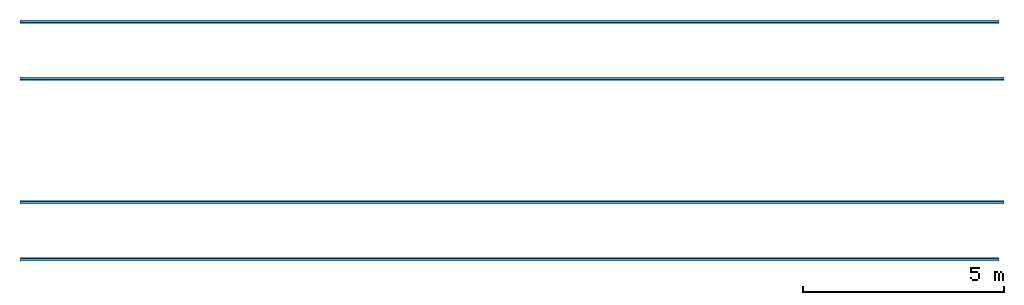
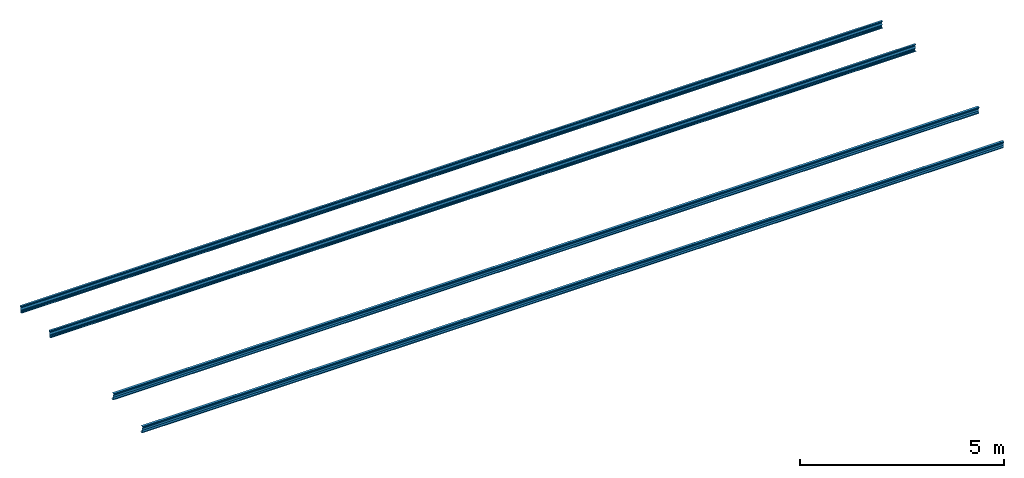
# One storey: 4 beams.
"""IFC2X3 building model written with IfcOpenShell, lengths in millimetres."""

from ifc_helpers import new_model, entity, si_unit, converted_unit, money_unit, point, direction, frame, frame_2d, origin_with_axes, place, context, subcontext, project, spatial, polyline, circle_curve, parameter, trimmed, segment, composite_curve, outline, extrude, material, type_object, element, save


model = new_model("IFC2X3")

# Units and contexts
model_context = context("Model", 3, precision=1e-05, world=origin_with_axes(), true_north=direction((0.0, 1.0)))
body_context = subcontext(model_context, "Body", "Model", "MODEL_VIEW")
ifc_project = project(units=[si_unit("LENGTHUNIT", "METRE", prefix="MILLI"), si_unit("AREAUNIT", "SQUARE_METRE"), si_unit("VOLUMEUNIT", "CUBIC_METRE"), converted_unit("PLANEANGLEUNIT", "DEGREE", entity("IfcPlaneAngleMeasure", 0.0174532925199), si_unit("PLANEANGLEUNIT", "RADIAN"), dimensions=[0, 0, 0, 0, 0, 0, 0]), si_unit("SOLIDANGLEUNIT", "STERADIAN"), money_unit("USD"), converted_unit("TIMEUNIT", "Year", entity("IfcTimeMeasure", 31556926.0), si_unit("TIMEUNIT", "SECOND"), dimensions=[0, 0, 0, 0, 0, 0, 0]), si_unit("MASSUNIT", "GRAM"), si_unit("THERMODYNAMICTEMPERATUREUNIT", "DEGREE_CELSIUS"), si_unit("LUMINOUSINTENSITYUNIT", "LUMEN")], contexts=[model_context])

# Site, building, storey
site_placement = place(None, origin_with_axes())
site = spatial("IfcSite", under=ifc_project, at=site_placement, CompositionType="ELEMENT")
building_placement = place(site_placement, origin_with_axes())
building = spatial("IfcBuilding", under=site, at=building_placement, CompositionType="ELEMENT")
storey_placement = place(building_placement, frame((0.0, 0.0, 74605.0), z_axis=(0.0, 0.0, 1.0), x_axis=(1.0, 0.0, 0.0)))
storey = spatial("IfcBuildingStorey", under=building, at=storey_placement, CompositionType="ELEMENT", Elevation=74605.0)

# Beams
ifc_material = material(Name="Metal - Steel 43-275")
beam_type_1 = type_object("IfcBeamType", PredefinedType="NOTDEFINED")
beam_1_placement = place(storey_placement, frame((16408.2045075, 5111.90364585, -29.9916343169), z_axis=(0.0, 0.0, 1.0), x_axis=(0.0, 1.0, 0.0)))
element("IfcBeam", 1, at=beam_1_placement, inside=storey, type_object=beam_type_1, material=ifc_material, Name="Light Gauge-Kingspan Purlins:M", ObjectType="Light Gauge-Kingspan Purlins:M", context=body_context, shape_type="SweptSolid", body=[
    extrude(outline(composite_curve([segment(polyline([(-33.5333333333, -102.5), (25.0666666666, -102.5)]), True, "CONTINUOUS"), segment(trimmed(circle_curve(frame_2d((25.0666666666, -99.3), x_axis=(0.0, -1.0)), 3.2), [point((25.0666666666, -102.5)), parameter(0.0)], [point((28.2666666666, -99.3)), parameter(90.0)], True, "CARTESIAN"), True, "CONTINUOUS"), segment(polyline([(28.2666666666, -99.3), (28.2666666666, -91.7)]), True, "CONTINUOUS"), segment(trimmed(circle_curve(frame_2d((25.0666666666, -91.7), x_axis=(1.0, 0.0)), 3.2), [point((28.2666666666, -91.7)), parameter(0.0)], [point((25.0666666666, -88.5)), parameter(90.0)], True, "CARTESIAN"), True, "CONTINUOUS"), segment(polyline([(25.0666666666, -88.5), (16.2666666666, -88.5), (16.2666666666, -90.1), (25.0666666666, -90.1)]), True, "CONTINUOUS"), segment(trimmed(circle_curve(frame_2d((25.0666666666, -91.7), x_axis=(1.0, 0.0)), 1.6), [point((25.0666666666, -90.1)), parameter(90.0)], [point((26.6666666666, -91.7)), parameter(0.0)], False, "CARTESIAN"), True, "CONTINUOUS"), segment(polyline([(26.6666666666, -91.7), (26.6666666666, -99.3)]), True, "CONTINUOUS"), segment(trimmed(circle_curve(frame_2d((25.0666666666, -99.3), x_axis=(0.0, -1.0)), 1.6), [point((26.6666666666, -99.3)), parameter(90.0)], [point((25.0666666666, -100.9)), parameter(0.0)], False, "CARTESIAN"), True, "CONTINUOUS"), segment(polyline([(25.0666666666, -100.9), (-33.5333333334, -100.9)]), True, "CONTINUOUS"), segment(trimmed(circle_curve(frame_2d((-33.5333333334, -99.3), x_axis=(-1.0, 0.0)), 1.6), [point((-33.5333333334, -100.9)), parameter(90.0)], [point((-35.1333333334, -99.3)), parameter(0.0)], False, "CARTESIAN"), True, "CONTINUOUS"), segment(polyline([(-35.1333333334, -99.3), (-35.1333333334, -70.8953456886), (-15.1333333334, -32.8953456886), (-15.1333333334, 32.8953456886), (-35.1333333334, 70.8953456886), (-35.1333333334, 99.3)]), True, "CONTINUOUS"), segment(trimmed(circle_curve(frame_2d((-33.5333333334, 99.3), x_axis=(0.0, 1.0)), 1.6), [point((-35.1333333334, 99.3)), parameter(90.0)], [point((-33.5333333334, 100.9)), parameter(0.0)], False, "CARTESIAN"), True, "CONTINUOUS"), segment(polyline([(-33.5333333334, 100.9), (25.0666666666, 100.9)]), True, "CONTINUOUS"), segment(trimmed(circle_curve(frame_2d((25.0666666666, 99.3), x_axis=(1.0, 0.0)), 1.6), [point((25.0666666666, 100.9)), parameter(90.0)], [point((26.6666666666, 99.3)), parameter(0.0)], False, "CARTESIAN"), True, "CONTINUOUS"), segment(polyline([(26.6666666666, 99.3), (26.6666666666, 91.7)]), True, "CONTINUOUS"), segment(trimmed(circle_curve(frame_2d((25.0666666666, 91.7), x_axis=(0.0, -1.0)), 1.6), [point((26.6666666666, 91.7)), parameter(90.0)], [point((25.0666666666, 90.1)), parameter(0.0)], False, "CARTESIAN"), True, "CONTINUOUS"), segment(polyline([(25.0666666666, 90.1), (16.2666666666, 90.1), (16.2666666666, 88.5), (25.0666666666, 88.5)]), True, "CONTINUOUS"), segment(trimmed(circle_curve(frame_2d((25.0666666666, 91.7), x_axis=(0.0, -1.0)), 3.2), [point((25.0666666666, 88.5)), parameter(0.0)], [point((28.2666666666, 91.7)), parameter(90.0)], True, "CARTESIAN"), True, "CONTINUOUS"), segment(polyline([(28.2666666666, 91.7), (28.2666666666, 99.3)]), True, "CONTINUOUS"), segment(trimmed(circle_curve(frame_2d((25.0666666666, 99.3), x_axis=(1.0, 0.0)), 3.2), [point((28.2666666666, 99.3)), parameter(0.0)], [point((25.0666666666, 102.5)), parameter(90.0)], True, "CARTESIAN"), True, "CONTINUOUS"), segment(polyline([(25.0666666666, 102.5), (-33.5333333334, 102.5)]), True, "CONTINUOUS"), segment(trimmed(circle_curve(frame_2d((-33.5333333334, 99.3), x_axis=(0.0, 1.0)), 3.2), [point((-33.5333333334, 102.5)), parameter(0.0)], [point((-36.7333333334, 99.3)), parameter(90.0)], True, "CARTESIAN"), True, "CONTINUOUS"), segment(polyline([(-36.7333333334, 99.3), (-36.7333333334, 70.5), (-16.7333333334, 32.5), (-16.7333333334, -32.5), (-36.7333333334, -70.5), (-36.7333333334, -99.3)]), True, "CONTINUOUS"), segment(trimmed(circle_curve(frame_2d((-33.5333333334, -99.3), x_axis=(-1.0, 0.0)), 3.20000000005), [point((-36.7333333334, -99.3)), parameter(0.0)], [point((-33.5333333333, -102.5)), parameter(90.0)], True, "CARTESIAN"), True, "CONTINUOUS")], self_intersect=False)), frame((0.0, 24528.0, 0.0), z_axis=(0.0, -1.0, 0.0), x_axis=(-0.996194698092, 0.0, 0.0871557427478)), (0.0, 0.0, 1.0), 24528.0),
])
beam_2_placement = place(storey_placement, frame((16287.2045075, 6534.46967472, -154.450034961), z_axis=(0.0, 0.0, 1.0), x_axis=(0.0, 1.0, 0.0)))
element("IfcBeam", 2, at=beam_2_placement, inside=storey, type_object=beam_type_1, material=ifc_material, Name="Light Gauge-Kingspan Purlins:M", ObjectType="Light Gauge-Kingspan Purlins:M", context=body_context, shape_type="SweptSolid", body=[
    extrude(outline(composite_curve([segment(polyline([(-33.5333333333, -102.5), (25.0666666666, -102.5)]), True, "CONTINUOUS"), segment(trimmed(circle_curve(frame_2d((25.0666666666, -99.3), x_axis=(0.0, -1.0)), 3.2), [point((25.0666666666, -102.5)), parameter(0.0)], [point((28.2666666666, -99.3)), parameter(90.0)], True, "CARTESIAN"), True, "CONTINUOUS"), segment(polyline([(28.2666666666, -99.3), (28.2666666666, -91.7)]), True, "CONTINUOUS"), segment(trimmed(circle_curve(frame_2d((25.0666666666, -91.7), x_axis=(1.0, 0.0)), 3.2), [point((28.2666666666, -91.7)), parameter(0.0)], [point((25.0666666666, -88.5)), parameter(90.0)], True, "CARTESIAN"), True, "CONTINUOUS"), segment(polyline([(25.0666666666, -88.5), (16.2666666666, -88.5), (16.2666666666, -90.1), (25.0666666666, -90.1)]), True, "CONTINUOUS"), segment(trimmed(circle_curve(frame_2d((25.0666666666, -91.7), x_axis=(1.0, 0.0)), 1.6), [point((25.0666666666, -90.1)), parameter(90.0)], [point((26.6666666666, -91.7)), parameter(0.0)], False, "CARTESIAN"), True, "CONTINUOUS"), segment(polyline([(26.6666666666, -91.7), (26.6666666666, -99.3)]), True, "CONTINUOUS"), segment(trimmed(circle_curve(frame_2d((25.0666666666, -99.3), x_axis=(0.0, -1.0)), 1.6), [point((26.6666666666, -99.3)), parameter(90.0)], [point((25.0666666666, -100.9)), parameter(0.0)], False, "CARTESIAN"), True, "CONTINUOUS"), segment(polyline([(25.0666666666, -100.9), (-33.5333333334, -100.9)]), True, "CONTINUOUS"), segment(trimmed(circle_curve(frame_2d((-33.5333333334, -99.3), x_axis=(-1.0, 0.0)), 1.6), [point((-33.5333333334, -100.9)), parameter(90.0)], [point((-35.1333333334, -99.3)), parameter(0.0)], False, "CARTESIAN"), True, "CONTINUOUS"), segment(polyline([(-35.1333333334, -99.3), (-35.1333333334, -70.8953456886), (-15.1333333334, -32.8953456886), (-15.1333333334, 32.8953456886), (-35.1333333334, 70.8953456886), (-35.1333333334, 99.3)]), True, "CONTINUOUS"), segment(trimmed(circle_curve(frame_2d((-33.5333333334, 99.3), x_axis=(0.0, 1.0)), 1.6), [point((-35.1333333334, 99.3)), parameter(90.0)], [point((-33.5333333334, 100.9)), parameter(0.0)], False, "CARTESIAN"), True, "CONTINUOUS"), segment(polyline([(-33.5333333334, 100.9), (25.0666666666, 100.9)]), True, "CONTINUOUS"), segment(trimmed(circle_curve(frame_2d((25.0666666666, 99.3), x_axis=(1.0, 0.0)), 1.6), [point((25.0666666666, 100.9)), parameter(90.0)], [point((26.6666666666, 99.3)), parameter(0.0)], False, "CARTESIAN"), True, "CONTINUOUS"), segment(polyline([(26.6666666666, 99.3), (26.6666666666, 91.7)]), True, "CONTINUOUS"), segment(trimmed(circle_curve(frame_2d((25.0666666666, 91.7), x_axis=(0.0, -1.0)), 1.6), [point((26.6666666666, 91.7)), parameter(90.0)], [point((25.0666666666, 90.1)), parameter(0.0)], False, "CARTESIAN"), True, "CONTINUOUS"), segment(polyline([(25.0666666666, 90.1), (16.2666666666, 90.1), (16.2666666666, 88.5), (25.0666666666, 88.5)]), True, "CONTINUOUS"), segment(trimmed(circle_curve(frame_2d((25.0666666666, 91.7), x_axis=(0.0, -1.0)), 3.2), [point((25.0666666666, 88.5)), parameter(0.0)], [point((28.2666666666, 91.7)), parameter(90.0)], True, "CARTESIAN"), True, "CONTINUOUS"), segment(polyline([(28.2666666666, 91.7), (28.2666666666, 99.3)]), True, "CONTINUOUS"), segment(trimmed(circle_curve(frame_2d((25.0666666666, 99.3), x_axis=(1.0, 0.0)), 3.2), [point((28.2666666666, 99.3)), parameter(0.0)], [point((25.0666666666, 102.5)), parameter(90.0)], True, "CARTESIAN"), True, "CONTINUOUS"), segment(polyline([(25.0666666666, 102.5), (-33.5333333334, 102.5)]), True, "CONTINUOUS"), segment(trimmed(circle_curve(frame_2d((-33.5333333334, 99.3), x_axis=(0.0, 1.0)), 3.2), [point((-33.5333333334, 102.5)), parameter(0.0)], [point((-36.7333333334, 99.3)), parameter(90.0)], True, "CARTESIAN"), True, "CONTINUOUS"), segment(polyline([(-36.7333333334, 99.3), (-36.7333333334, 70.5), (-16.7333333334, 32.5), (-16.7333333334, -32.5), (-36.7333333334, -70.5), (-36.7333333334, -99.3)]), True, "CONTINUOUS"), segment(trimmed(circle_curve(frame_2d((-33.5333333334, -99.3), x_axis=(-1.0, 0.0)), 3.20000000005), [point((-36.7333333334, -99.3)), parameter(0.0)], [point((-33.5333333333, -102.5)), parameter(90.0)], True, "CARTESIAN"), True, "CONTINUOUS")], self_intersect=False)), frame((0.0, 24407.0, 0.0), z_axis=(0.0, -1.0, 0.0), x_axis=(-0.996194698092, 0.0, 0.0871557427478)), (0.0, 0.0, 1.0), 24407.0),
])
beam_type_2 = type_object("IfcBeamType", PredefinedType="NOTDEFINED")
beam_3_placement = place(storey_placement, frame((16287.2045075, 620.490168663, -154.450034961), z_axis=(0.0, 0.0, 1.0), x_axis=(0.0, 1.0, 0.0)))
element("IfcBeam", 3, at=beam_3_placement, inside=storey, type_object=beam_type_2, material=ifc_material, Name="Light Gauge-Kingspan Purlins:M", ObjectType="Light Gauge-Kingspan Purlins:M", context=body_context, shape_type="SweptSolid", body=[
    extrude(outline(composite_curve([segment(polyline([(91.7, -28.2666666667), (99.3, -28.2666666667)]), True, "CONTINUOUS"), segment(trimmed(circle_curve(frame_2d((99.3, -25.0666666667), x_axis=(0.0, -1.0)), 3.2), [point((99.3, -28.2666666667)), parameter(0.0)], [point((102.5, -25.0666666667)), parameter(90.0)], True, "CARTESIAN"), True, "CONTINUOUS"), segment(polyline([(102.5, -25.0666666667), (102.5, 33.5333333333)]), True, "CONTINUOUS"), segment(trimmed(circle_curve(frame_2d((99.3, 33.5333333333), x_axis=(1.0, 0.0)), 3.2), [point((102.5, 33.5333333333)), parameter(0.0)], [point((99.3, 36.7333333333)), parameter(90.0)], True, "CARTESIAN"), True, "CONTINUOUS"), segment(polyline([(99.3, 36.7333333333), (70.5, 36.7333333333), (32.5, 16.7333333333), (-32.5, 16.7333333333), (-70.5, 36.7333333334), (-99.3, 36.7333333334)]), True, "CONTINUOUS"), segment(trimmed(circle_curve(frame_2d((-99.3, 33.5333333334), x_axis=(0.0, 1.0)), 3.2), [point((-99.3, 36.7333333334)), parameter(0.0)], [point((-102.5, 33.5333333334)), parameter(90.0)], True, "CARTESIAN"), True, "CONTINUOUS"), segment(polyline([(-102.5, 33.5333333334), (-102.5, -25.0666666666)]), True, "CONTINUOUS"), segment(trimmed(circle_curve(frame_2d((-99.3, -25.0666666666), x_axis=(-1.0, 0.0)), 3.2), [point((-102.5, -25.0666666666)), parameter(0.0)], [point((-99.3, -28.2666666666)), parameter(90.0)], True, "CARTESIAN"), True, "CONTINUOUS"), segment(polyline([(-99.3, -28.2666666666), (-91.7, -28.2666666666)]), True, "CONTINUOUS"), segment(trimmed(circle_curve(frame_2d((-91.7, -25.0666666666), x_axis=(0.0, -1.0)), 3.2), [point((-91.7, -28.2666666666)), parameter(0.0)], [point((-88.5, -25.0666666666)), parameter(90.0)], True, "CARTESIAN"), True, "CONTINUOUS"), segment(polyline([(-88.5, -25.0666666666), (-88.5, -16.2666666666), (-90.1, -16.2666666666), (-90.1, -25.0666666666)]), True, "CONTINUOUS"), segment(trimmed(circle_curve(frame_2d((-91.7, -25.0666666666), x_axis=(0.0, -1.0)), 1.6), [point((-90.1, -25.0666666666)), parameter(90.0)], [point((-91.7, -26.6666666666)), parameter(0.0)], False, "CARTESIAN"), True, "CONTINUOUS"), segment(polyline([(-91.7, -26.6666666666), (-99.3, -26.6666666666)]), True, "CONTINUOUS"), segment(trimmed(circle_curve(frame_2d((-99.3, -25.0666666666), x_axis=(-1.0, 0.0)), 1.6), [point((-99.3, -26.6666666666)), parameter(90.0)], [point((-100.9, -25.0666666666)), parameter(0.0)], False, "CARTESIAN"), True, "CONTINUOUS"), segment(polyline([(-100.9, -25.0666666666), (-100.9, 33.5333333334)]), True, "CONTINUOUS"), segment(trimmed(circle_curve(frame_2d((-99.3, 33.5333333334), x_axis=(0.0, 1.0)), 1.6), [point((-100.9, 33.5333333334)), parameter(90.0)], [point((-99.3, 35.1333333334)), parameter(0.0)], False, "CARTESIAN"), True, "CONTINUOUS"), segment(polyline([(-99.3, 35.1333333334), (-70.8953456886, 35.1333333334), (-32.8953456886, 15.1333333333), (32.8953456886, 15.1333333333), (70.8953456886, 35.1333333333), (99.3, 35.1333333333)]), True, "CONTINUOUS"), segment(trimmed(circle_curve(frame_2d((99.3, 33.5333333333), x_axis=(1.0, 0.0)), 1.6), [point((99.3, 35.1333333333)), parameter(90.0)], [point((100.9, 33.5333333333)), parameter(0.0)], False, "CARTESIAN"), True, "CONTINUOUS"), segment(polyline([(100.9, 33.5333333333), (100.9, -25.0666666667)]), True, "CONTINUOUS"), segment(trimmed(circle_curve(frame_2d((99.3, -25.0666666667), x_axis=(0.0, -1.0)), 1.6), [point((100.9, -25.0666666667)), parameter(90.0)], [point((99.3, -26.6666666667)), parameter(0.0)], False, "CARTESIAN"), True, "CONTINUOUS"), segment(polyline([(99.3, -26.6666666667), (91.7, -26.6666666667)]), True, "CONTINUOUS"), segment(trimmed(circle_curve(frame_2d((91.7, -25.0666666667), x_axis=(-1.0, 0.0)), 1.6), [point((91.7, -26.6666666667)), parameter(90.0)], [point((90.1, -25.0666666667)), parameter(0.0)], False, "CARTESIAN"), True, "CONTINUOUS"), segment(polyline([(90.1, -25.0666666667), (90.1, -16.2666666667), (88.5, -16.2666666667), (88.5, -25.0666666667)]), True, "CONTINUOUS"), segment(trimmed(circle_curve(frame_2d((91.7, -25.0666666667), x_axis=(-1.0, 0.0)), 3.2), [point((88.5, -25.0666666667)), parameter(0.0)], [point((91.7, -28.2666666667)), parameter(90.0)], True, "CARTESIAN"), True, "CONTINUOUS")], self_intersect=False)), frame((0.0, 24407.0, 0.0), z_axis=(0.0, -1.0, 0.0), x_axis=(-0.0871557427479, 0.0, 0.996194698092)), (0.0, 0.0, 1.0), 24407.0),
])
beam_4_placement = place(storey_placement, frame((16408.2045075, 2043.05619754, -29.9916343169), z_axis=(0.0, 0.0, 1.0), x_axis=(0.0, 1.0, 0.0)))
element("IfcBeam", 4, at=beam_4_placement, inside=storey, type_object=beam_type_2, material=ifc_material, Name="Light Gauge-Kingspan Purlins:M", ObjectType="Light Gauge-Kingspan Purlins:M", context=body_context, shape_type="SweptSolid", body=[
    extrude(outline(composite_curve([segment(polyline([(91.7, -28.2666666667), (99.3, -28.2666666667)]), True, "CONTINUOUS"), segment(trimmed(circle_curve(frame_2d((99.3, -25.0666666667), x_axis=(0.0, -1.0)), 3.2), [point((99.3, -28.2666666667)), parameter(0.0)], [point((102.5, -25.0666666667)), parameter(90.0)], True, "CARTESIAN"), True, "CONTINUOUS"), segment(polyline([(102.5, -25.0666666667), (102.5, 33.5333333333)]), True, "CONTINUOUS"), segment(trimmed(circle_curve(frame_2d((99.3, 33.5333333333), x_axis=(1.0, 0.0)), 3.2), [point((102.5, 33.5333333333)), parameter(0.0)], [point((99.3, 36.7333333333)), parameter(90.0)], True, "CARTESIAN"), True, "CONTINUOUS"), segment(polyline([(99.3, 36.7333333333), (70.5, 36.7333333333), (32.5, 16.7333333333), (-32.5, 16.7333333333), (-70.5, 36.7333333334), (-99.3, 36.7333333334)]), True, "CONTINUOUS"), segment(trimmed(circle_curve(frame_2d((-99.3, 33.5333333334), x_axis=(0.0, 1.0)), 3.2), [point((-99.3, 36.7333333334)), parameter(0.0)], [point((-102.5, 33.5333333334)), parameter(90.0)], True, "CARTESIAN"), True, "CONTINUOUS"), segment(polyline([(-102.5, 33.5333333334), (-102.5, -25.0666666666)]), True, "CONTINUOUS"), segment(trimmed(circle_curve(frame_2d((-99.3, -25.0666666666), x_axis=(-1.0, 0.0)), 3.2), [point((-102.5, -25.0666666666)), parameter(0.0)], [point((-99.3, -28.2666666666)), parameter(90.0)], True, "CARTESIAN"), True, "CONTINUOUS"), segment(polyline([(-99.3, -28.2666666666), (-91.7, -28.2666666666)]), True, "CONTINUOUS"), segment(trimmed(circle_curve(frame_2d((-91.7, -25.0666666666), x_axis=(0.0, -1.0)), 3.2), [point((-91.7, -28.2666666666)), parameter(0.0)], [point((-88.5, -25.0666666666)), parameter(90.0)], True, "CARTESIAN"), True, "CONTINUOUS"), segment(polyline([(-88.5, -25.0666666666), (-88.5, -16.2666666666), (-90.1, -16.2666666666), (-90.1, -25.0666666666)]), True, "CONTINUOUS"), segment(trimmed(circle_curve(frame_2d((-91.7, -25.0666666666), x_axis=(0.0, -1.0)), 1.6), [point((-90.1, -25.0666666666)), parameter(90.0)], [point((-91.7, -26.6666666666)), parameter(0.0)], False, "CARTESIAN"), True, "CONTINUOUS"), segment(polyline([(-91.7, -26.6666666666), (-99.3, -26.6666666666)]), True, "CONTINUOUS"), segment(trimmed(circle_curve(frame_2d((-99.3, -25.0666666666), x_axis=(-1.0, 0.0)), 1.6), [point((-99.3, -26.6666666666)), parameter(90.0)], [point((-100.9, -25.0666666666)), parameter(0.0)], False, "CARTESIAN"), True, "CONTINUOUS"), segment(polyline([(-100.9, -25.0666666666), (-100.9, 33.5333333334)]), True, "CONTINUOUS"), segment(trimmed(circle_curve(frame_2d((-99.3, 33.5333333334), x_axis=(0.0, 1.0)), 1.6), [point((-100.9, 33.5333333334)), parameter(90.0)], [point((-99.3, 35.1333333334)), parameter(0.0)], False, "CARTESIAN"), True, "CONTINUOUS"), segment(polyline([(-99.3, 35.1333333334), (-70.8953456886, 35.1333333334), (-32.8953456886, 15.1333333333), (32.8953456886, 15.1333333333), (70.8953456886, 35.1333333333), (99.3, 35.1333333333)]), True, "CONTINUOUS"), segment(trimmed(circle_curve(frame_2d((99.3, 33.5333333333), x_axis=(1.0, 0.0)), 1.6), [point((99.3, 35.1333333333)), parameter(90.0)], [point((100.9, 33.5333333333)), parameter(0.0)], False, "CARTESIAN"), True, "CONTINUOUS"), segment(polyline([(100.9, 33.5333333333), (100.9, -25.0666666667)]), True, "CONTINUOUS"), segment(trimmed(circle_curve(frame_2d((99.3, -25.0666666667), x_axis=(0.0, -1.0)), 1.6), [point((100.9, -25.0666666667)), parameter(90.0)], [point((99.3, -26.6666666667)), parameter(0.0)], False, "CARTESIAN"), True, "CONTINUOUS"), segment(polyline([(99.3, -26.6666666667), (91.7, -26.6666666667)]), True, "CONTINUOUS"), segment(trimmed(circle_curve(frame_2d((91.7, -25.0666666667), x_axis=(-1.0, 0.0)), 1.6), [point((91.7, -26.6666666667)), parameter(90.0)], [point((90.1, -25.0666666667)), parameter(0.0)], False, "CARTESIAN"), True, "CONTINUOUS"), segment(polyline([(90.1, -25.0666666667), (90.1, -16.2666666667), (88.5, -16.2666666667), (88.5, -25.0666666667)]), True, "CONTINUOUS"), segment(trimmed(circle_curve(frame_2d((91.7, -25.0666666667), x_axis=(-1.0, 0.0)), 3.2), [point((88.5, -25.0666666667)), parameter(0.0)], [point((91.7, -28.2666666667)), parameter(90.0)], True, "CARTESIAN"), True, "CONTINUOUS")], self_intersect=False)), frame((0.0, 24528.0, 0.0), z_axis=(0.0, -1.0, 0.0), x_axis=(-0.0871557427479, 0.0, 0.996194698092)), (0.0, 0.0, 1.0), 24528.0),
])

save(model, "model.ifc")
